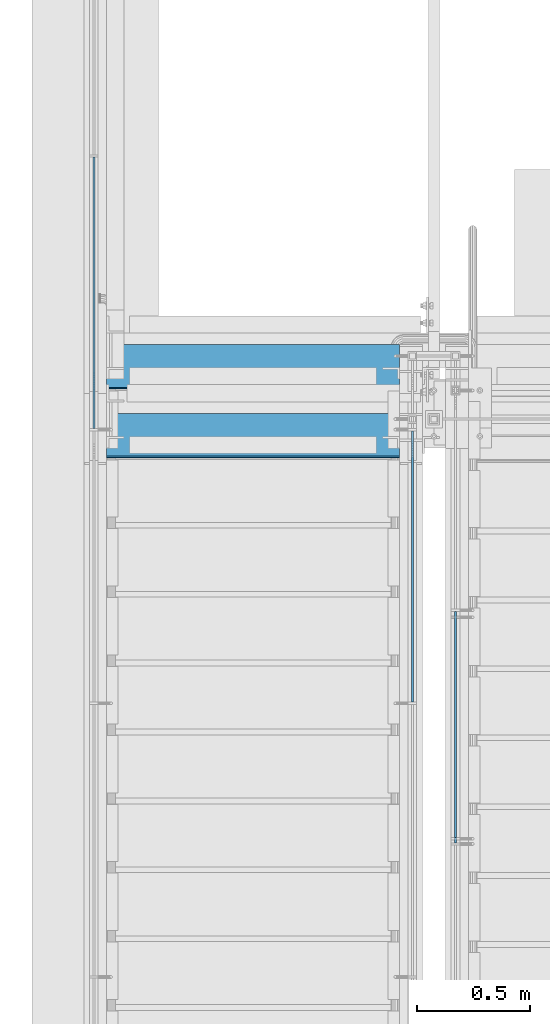
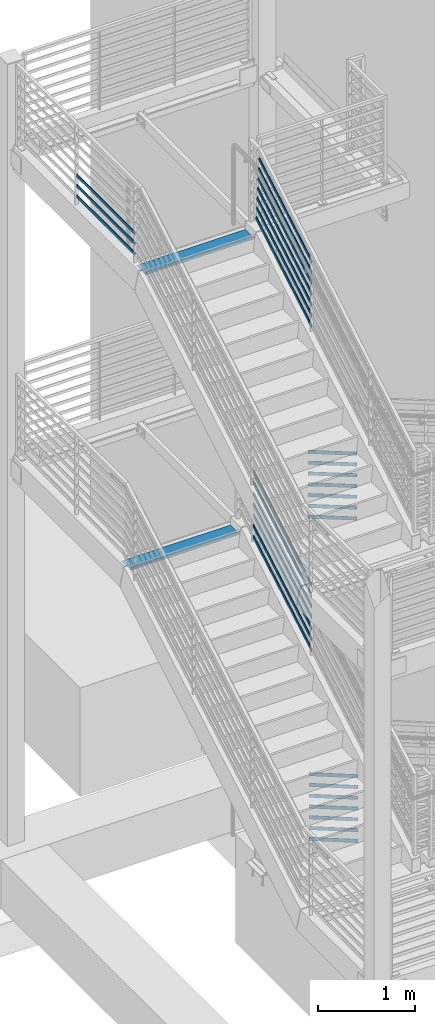
# One storey, part 758 of 1179: 28 members, 5 beams, 7 elements without a shape of their own.
"""IFC2X3 building model written with IfcOpenShell, lengths in millimetres."""

import ifcopenshell
import ifcopenshell.guid

model = None  # the IFC model being written
_history = None  # IfcOwnerHistory: only IFC2X3 demands one
_inside = {}  # id of a spatial element -> (the spatial element, [elements in it])
_under = {}  # id of a project, library or spatial element -> (it, [spatial elements below it])
_declared = {}  # id of a project -> (the project, [libraries it declares])
_typed = {}  # id of a type object -> (the type object, [elements of that type])
_made_of = {}  # id of a material, layer set ... -> (it, [elements and type objects made of it])


def new_model(schema):
    """Start an empty IFC model of exactly this schema.

    Asked for "IFC4X3", IfcOpenShell would pick the latest addendum, in which some entities
    have other attributes; the version numbers below select the first issue.
    IFC2X3 requires an IfcOwnerHistory on every rooted entity: one is made here for all.
    """
    global model, _history
    if schema == "IFC4X3":
        model = ifcopenshell.file(schema_version=(4, 3, 0, 0))
    else:
        model = ifcopenshell.file(schema=schema)
    _inside.clear()
    _under.clear()
    _declared.clear()
    _typed.clear()
    _made_of.clear()
    _history = None
    if model.schema == "IFC2X3":
        org = make("IfcOrganization", Name="unknown")
        user = make(
            "IfcPersonAndOrganization",
            ThePerson=make("IfcPerson", FamilyName="unknown"),
            TheOrganization=org,
        )
        app = make(
            "IfcApplication",
            ApplicationDeveloper=org,
            Version="unknown",
            ApplicationFullName="unknown",
            ApplicationIdentifier="unknown",
        )
        _history = make(
            "IfcOwnerHistory",
            OwningUser=user,
            OwningApplication=app,
            ChangeAction="ADDED",
            CreationDate=0,
        )
    return model


def make(cls, **values):
    """One entity of the class cls with the attributes given. An attribute that is None is left unset."""
    return model.create_entity(
        cls, **{name: value for name, value in values.items() if value is not None}
    )


def rooted(cls, **values):
    """An entity with a GlobalId (a new one), such as an element, a storey or a relation."""
    return make(cls, GlobalId=ifcopenshell.guid.new(), OwnerHistory=_history, **values)


def si_unit(unit_type, name, prefix=None):
    """IfcSIUnit, for example si_unit("LENGTHUNIT", "METRE", prefix="MILLI")."""
    return make("IfcSIUnit", UnitType=unit_type, Prefix=prefix, Name=name)


def assignment(units):
    """IfcUnitAssignment: the units of a project."""
    return None if units is None else make("IfcUnitAssignment", Units=units)


def point(xyz):
    """IfcCartesianPoint."""
    return None if xyz is None else make("IfcCartesianPoint", Coordinates=xyz)


def direction(xyz):
    """IfcDirection."""
    return None if xyz is None else make("IfcDirection", DirectionRatios=xyz)


def frame(location, z_axis=None, x_axis=None):
    """IfcAxis2Placement3D, a coordinate frame: its origin and axes. An axis left out is left unset."""
    return make(
        "IfcAxis2Placement3D",
        Location=point(location),
        Axis=direction(z_axis),
        RefDirection=direction(x_axis),
    )


def origin_with_axes():
    """The frame at (0, 0, 0) with the z axis (0, 0, 1) and the x axis (1, 0, 0) written out."""
    return frame((0.0, 0.0, 0.0), z_axis=(0.0, 0.0, 1.0), x_axis=(1.0, 0.0, 0.0))


def place(relative_to, where):
    """IfcLocalPlacement: puts the frame where relative to a parent placement (None: the world)."""
    return make(
        "IfcLocalPlacement", PlacementRelTo=relative_to, RelativePlacement=where
    )


def context(
    kind, dimensions, precision=None, world=None, true_north=None, identifier=None
):
    """IfcGeometricRepresentationContext, for example the 3D "Model" context."""
    return make(
        "IfcGeometricRepresentationContext",
        ContextIdentifier=identifier,
        ContextType=kind,
        CoordinateSpaceDimension=dimensions,
        Precision=precision,
        WorldCoordinateSystem=world,
        TrueNorth=true_north,
    )


def subcontext(parent, identifier, kind, view, scale=None):
    """IfcGeometricRepresentationSubContext, for example "Body" below "Model"."""
    return make(
        "IfcGeometricRepresentationSubContext",
        ContextIdentifier=identifier,
        ContextType=kind,
        ParentContext=parent,
        TargetScale=scale,
        TargetView=view,
    )


def project(units=None, contexts=None):
    """IfcProject with its units and contexts."""
    return rooted(
        "IfcProject",
        Name="project",
        RepresentationContexts=contexts,
        UnitsInContext=assignment(units),
    )


def spatial(cls, under=None, at=None, **own):
    """A site, building, storey or space (cls), placed at a placement, below another one or the project."""
    s = rooted(cls, ObjectPlacement=at, **own)
    if under is not None:
        _under.setdefault(under.id(), (under, []))[1].append(s)
    return s


def faces_of(points, faces, orient=None, outer=None):
    """IfcFace entities. A face is a list of loops; a loop is a list of indices into points, from 0.

    orient and outer hold one flag for each loop. By default every Orientation is true, the
    first loop of a face is its IfcFaceOuterBound and the others are IfcFaceBound.
    """
    made = []
    for i, loops in enumerate(faces):
        bounds = []
        for j, loop in enumerate(loops):
            is_outer = j == 0 if outer is None else outer[i][j]
            bounds.append(
                make(
                    "IfcFaceOuterBound" if is_outer else "IfcFaceBound",
                    Bound=make("IfcPolyLoop", Polygon=[points[k] for k in loop]),
                    Orientation=True if orient is None else orient[i][j],
                )
            )
        made.append(make("IfcFace", Bounds=bounds))
    return made


def faceted_brep(points, faces, orient=None, outer=None, voids=None):
    """IfcFacetedBrep: a solid bounded by flat faces; with voids (closed shells), ...WithVoids."""
    shared = [point(p) for p in points]
    hull = make("IfcClosedShell", CfsFaces=faces_of(shared, faces, orient, outer))
    if voids is None:
        return make("IfcFacetedBrep", Outer=hull)
    return make(
        "IfcFacetedBrepWithVoids",
        Outer=hull,
        Voids=[
            make(cls, CfsFaces=faces_of(shared, fs, o, b)) for cls, fs, o, b in voids
        ],
    )


def shape(context_of_items, identifier, shape_type, items):
    """IfcShapeRepresentation: the items that make up one representation, for example the "Body"."""
    return make(
        "IfcShapeRepresentation",
        ContextOfItems=context_of_items,
        RepresentationIdentifier=identifier,
        RepresentationType=shape_type,
        Items=items,
    )


def material(Name=None, Category=None):
    """IfcMaterial."""
    return make("IfcMaterial", Name=Name, Category=Category)


def made_of(thing, what):
    """Note that an element or type object is made of a material, layer set ...; save() writes the relation."""
    if what is not None:
        _made_of.setdefault(what.id(), (what, []))[1].append(thing)
    return thing


def type_object(cls, material=None, **own):
    """A type object (cls), such as IfcWallType, which elements share."""
    return made_of(rooted(cls, **own), material)


def element(
    cls,
    number,
    at=None,
    inside=None,
    cuts=None,
    type_object=None,
    material=None,
    context=None,
    identifier="Body",
    shape_type=None,
    held_by="IfcProductDefinitionShape",
    body=None,
    shapes=None,
    **own,
):
    """One element of the class cls, such as IfcWall. Its Tag is "e" and its number.

    at: its placement. inside: the storey or other place that contains it. cuts: it is an
    opening in that element (IfcRelVoidsElement). A single representation is given by context,
    identifier, shape_type and body (its items); several are given by shapes. held_by: the class
    of the entity that holds the representations. save() writes the other relations.
    """
    e = rooted(cls, Tag="e%d" % number, ObjectPlacement=at, **own)
    if body is not None:
        shapes = [shape(context, identifier, shape_type, body)]
    if shapes is not None:
        e.Representation = make(held_by, Representations=shapes)
    if inside is not None:
        _inside.setdefault(inside.id(), (inside, []))[1].append(e)
    if cuts is not None:
        rooted(
            "IfcRelVoidsElement", RelatingBuildingElement=cuts, RelatedOpeningElement=e
        )
    if type_object is not None:
        _typed.setdefault(type_object.id(), (type_object, []))[1].append(e)
    return made_of(e, material)


def aggregate(whole, parts):
    """IfcRelAggregates: a whole, such as a stair, and the parts it consists of."""
    return rooted("IfcRelAggregates", RelatingObject=whole, RelatedObjects=parts)


def save(model, path):
    """Write the relations noted so far, then the file.

    IfcRelAggregates (storeys below a building ...), IfcRelContainedInSpatialStructure (elements
    in a storey), IfcRelDefinesByType, IfcRelAssociatesMaterial and IfcRelDeclares: one each for
    every whole, place, type object, material and project.
    """
    for whole, parts in _under.values():
        aggregate(whole, parts)
    for where, things in _inside.values():
        rooted(
            "IfcRelContainedInSpatialStructure",
            RelatedElements=things,
            RelatingStructure=where,
        )
    for kind, things in _typed.values():
        rooted("IfcRelDefinesByType", RelatedObjects=things, RelatingType=kind)
    for what, things in _made_of.values():
        rooted("IfcRelAssociatesMaterial", RelatedObjects=things, RelatingMaterial=what)
    for by, libraries in _declared.values():
        rooted("IfcRelDeclares", RelatingContext=by, RelatedDefinitions=libraries)
    model.write(path)


model = new_model("IFC2X3")

# Units and contexts
model_context = context("Model", 3, precision=1e-05, world=origin_with_axes())
body_context = subcontext(model_context, "Body", "Model", "MODEL_VIEW")
ifc_project = project(units=[si_unit("LENGTHUNIT", "METRE", prefix="MILLI"), si_unit("AREAUNIT", "SQUARE_METRE"), si_unit("VOLUMEUNIT", "CUBIC_METRE"), si_unit("MASSUNIT", "GRAM", prefix="KILO"), si_unit("TIMEUNIT", "SECOND"), si_unit("PLANEANGLEUNIT", "RADIAN"), si_unit("SOLIDANGLEUNIT", "STERADIAN"), si_unit("THERMODYNAMICTEMPERATUREUNIT", "DEGREE_CELSIUS"), si_unit("LUMINOUSINTENSITYUNIT", "LUMEN")], contexts=[model_context])

# Site, building, storey
site_placement = place(None, origin_with_axes())
site = spatial("IfcSite", under=ifc_project, at=site_placement, CompositionType="ELEMENT")
building_placement = place(site_placement, origin_with_axes())
building = spatial("IfcBuilding", under=site, at=building_placement, Name="Undefined", CompositionType="ELEMENT")
storey_placement = place(building_placement, origin_with_axes())
storey = spatial("IfcBuildingStorey", under=building, at=storey_placement, Name="Undefined", CompositionType="ELEMENT", Elevation=0.0)

# Assembly, beam
assembly_1_placement = place(storey_placement, origin_with_axes())
assembly_1 = element("IfcElementAssembly", 1, at=assembly_1_placement, inside=storey, Name="STRINGER", AssemblyPlace="NOTDEFINED", PredefinedType="RIGID_FRAME")
ifc_material = material(Name="STEEL/A36")
beam_type_1 = type_object("IfcBeamType", PredefinedType="NOTDEFINED")
beam_1_placement = place(assembly_1_placement, frame((-2552.70000000004, 34944.8910299301, 8130.51961359686), z_axis=(-1.0, 0.0, 0.0), x_axis=(0.0, 0.142453053944999, -0.989801559617757)))
beam_1 = element("IfcBeam", 2, at=beam_1_placement, type_object=beam_type_1, material=ifc_material, Name="TREAD", context=body_context, shape_type="Brep", body=[
    faceted_brep([(-5.47515810467303e-10, -1.58750000000146, -647.7), (-5.47515810467303e-10, -1.58750000000146, 647.7), (5.49334799870849e-10, 1.58749999999418, 647.7), (5.49334799870849e-10, 1.58749999999418, -647.7), (37.6019506244984, 1.58749998704297, 647.7), (37.6019506244984, 1.58749998704297, -647.7), (34.8511855571105, -1.58750001201406, -647.7), (34.8511855571105, -1.58750001201406, 647.7), (64.9848133561491, -188.675884943717, 647.7), (64.9848133561491, -188.675884943717, -647.7), (61.8421934043654, -189.128173390025, 647.7), (61.8421934043654, -189.128173390025, -647.7)], [[[0, 1, 2, 3]], [[3, 2, 4, 5]], [[1, 0, 6, 7]], [[5, 4, 8, 9]], [[4, 2, 1, 7, 10, 8]], [[7, 6, 11, 10]], [[6, 0, 3, 5, 9, 11]], [[10, 11, 9, 8]]]),
])
aggregate(assembly_1, [beam_1])

assembly_2_placement = place(storey_placement, origin_with_axes())
assembly_2 = element("IfcElementAssembly", 3, at=assembly_2_placement, inside=storey, Name="STRINGER", AssemblyPlace="NOTDEFINED", PredefinedType="RIGID_FRAME")
beam_2_placement = place(assembly_2_placement, frame((-2552.70000000004, 35249.6910299626, 4218.91961359472), z_axis=(-1.0, 0.0, 0.0), x_axis=(0.0, 0.142453053944999, -0.989801559617757)))
beam_2 = element("IfcBeam", 4, at=beam_2_placement, type_object=beam_type_1, material=ifc_material, Name="TREAD", context=body_context, shape_type="Brep", body=[
    faceted_brep([(-5.47515810467303e-10, -1.58750000000146, -647.7), (-5.47515810467303e-10, -1.58750000000146, 647.7), (5.49334799870849e-10, 1.58749999999418, 647.7), (5.49334799870849e-10, 1.58749999999418, -647.7), (37.6019506244984, 1.58749998704297, 647.7), (37.6019506244984, 1.58749998704297, -647.7), (34.8511855571105, -1.58750001201406, -647.7), (34.8511855571105, -1.58750001201406, 647.7), (64.9848133561491, -188.675884943717, 647.7), (64.9848133561491, -188.675884943717, -647.7), (61.8421934043654, -189.128173390025, 647.7), (61.8421934043654, -189.128173390025, -647.7)], [[[0, 1, 2, 3]], [[3, 2, 4, 5]], [[1, 0, 6, 7]], [[5, 4, 8, 9]], [[4, 2, 1, 7, 10, 8]], [[7, 6, 11, 10]], [[6, 0, 3, 5, 9, 11]], [[10, 11, 9, 8]]]),
])
aggregate(assembly_2, [beam_2])

# Assembly, beams
assembly_3_placement = place(storey_placement, origin_with_axes())
assembly_3 = element("IfcElementAssembly", 5, at=assembly_3_placement, inside=storey, Name="GUARDRAIL", AssemblyPlace="NOTDEFINED", PredefinedType="RIGID_FRAME")
beam_type_2 = type_object("IfcBeamType", PredefinedType="NOTDEFINED")
beam_3_placement = place(assembly_3_placement, frame((-3257.54999923555, 36279.6666666667, 8305.78812688398), z_axis=(0.0, 0.0, 1.0), x_axis=(0.0, -1.0, 0.0)))
beam_3 = element("IfcBeam", 6, at=beam_3_placement, type_object=beam_type_2, material=ifc_material, Name="PLATE", context=body_context, shape_type="Brep", body=[
    faceted_brep([(4.76250000197615, 4.76249999999999, -19.0500000000002), (4.76250000197615, 4.76249999999999, 19.0500000000002), (1205.97083333334, 4.76249999999982, 19.0499999999993), (1205.97083333334, 4.76249999999982, -19.0499999999993), (4.76250000197615, -4.76249999999999, 19.0500000000002), (1205.97083333334, -4.76249999999982, 19.0499999999993), (4.76250000197615, -4.76249999999999, -19.0500000000002), (1205.97083333334, -4.76249999999982, -19.0499999999993)], [[[0, 1, 2, 3]], [[1, 4, 5, 2]], [[4, 6, 7, 5]], [[6, 0, 3, 7]], [[5, 7, 3, 2]], [[6, 4, 1, 0]]]),
])
beam_4_placement = place(assembly_3_placement, frame((-3257.54999923555, 36279.6666666667, 8435.96312688397), z_axis=(0.0, 0.0, 1.0), x_axis=(0.0, -1.0, 0.0)))
beam_4 = element("IfcBeam", 7, at=beam_4_placement, type_object=beam_type_2, material=ifc_material, Name="PLATE", context=body_context, shape_type="Brep", body=[
    faceted_brep([(4.76250000197615, 4.76249999999999, -19.0500000000002), (4.76250000197615, 4.76249999999999, 19.0500000000002), (1205.97083333334, 4.76249999999982, 19.0499999999993), (1205.97083333334, 4.76249999999982, -19.0499999999993), (4.76250000197615, -4.76249999999999, 19.0500000000002), (1205.97083333334, -4.76249999999982, 19.0499999999993), (4.76250000197615, -4.76249999999999, -19.0500000000002), (1205.97083333334, -4.76249999999982, -19.0499999999993)], [[[0, 1, 2, 3]], [[1, 4, 5, 2]], [[4, 6, 7, 5]], [[6, 0, 3, 7]], [[5, 7, 3, 2]], [[6, 4, 1, 0]]]),
])
beam_5_placement = place(assembly_3_placement, frame((-3257.54999923555, 36279.6666666667, 8566.13812688397), z_axis=(0.0, 0.0, 1.0), x_axis=(0.0, -1.0, 0.0)))
beam_5 = element("IfcBeam", 8, at=beam_5_placement, type_object=beam_type_2, material=ifc_material, Name="PLATE", context=body_context, shape_type="Brep", body=[
    faceted_brep([(4.76250000197615, 4.76249999999999, -19.0500000000002), (4.76250000197615, 4.76249999999999, 19.0500000000002), (1205.97083333334, 4.76249999999982, 19.0499999999993), (1205.97083333334, 4.76249999999982, -19.0499999999993), (4.76250000197615, -4.76249999999999, 19.0500000000002), (1205.97083333334, -4.76249999999982, 19.0499999999993), (4.76250000197615, -4.76249999999999, -19.0500000000002), (1205.97083333334, -4.76249999999982, -19.0499999999993)], [[[0, 1, 2, 3]], [[1, 4, 5, 2]], [[4, 6, 7, 5]], [[6, 0, 3, 7]], [[5, 7, 3, 2]], [[6, 4, 1, 0]]]),
])
aggregate(assembly_3, [beam_3, beam_4, beam_5])

# Assembly, members
assembly_4_placement = place(storey_placement, origin_with_axes())
assembly_4 = element("IfcElementAssembly", 9, at=assembly_4_placement, inside=storey, Name="GUARDRAIL", AssemblyPlace="NOTDEFINED", PredefinedType="RIGID_FRAME")
member_type = type_object("IfcMemberType", PredefinedType="NOTDEFINED")
member_1_placement = place(assembly_4_placement, frame((-1847.85000153055, 35022.9653816585, 8312.30172653875), z_axis=(0.0, -0.503864876039814, 0.863782488068254), x_axis=(0.0, -0.863782488068254, -0.503864876039814)))
member_1 = element("IfcMember", 10, at=member_1_placement, type_object=member_type, material=ifc_material, Name="PLATE", context=body_context, shape_type="Brep", body=[
    faceted_brep([(18.0090376689841, 4.76250000000005, -19.0499999999538), (7.70888092478708, 4.76250000000005, 19.049999999992), (1331.82169315177, 4.76250000000005, 19.0500000018928), (1354.04632961107, 4.76250000000005, -19.0499999980329), (7.70888092478708, -4.76250000000005, 19.049999999992), (1331.82169315177, -4.76250000000005, 19.0500000018928), (18.0090376689841, -4.76250000000005, -19.0499999999538), (1354.04632961107, -4.76250000000005, -19.0499999980329)], [[[0, 1, 2, 3]], [[1, 4, 5, 2]], [[4, 6, 7, 5]], [[6, 0, 3, 7]], [[5, 7, 3, 2]], [[6, 4, 1, 0]]]),
])
member_2_placement = place(assembly_4_placement, frame((-1847.85000153055, 35012.0608890004, 8442.13530455055), z_axis=(0.0, -0.503871025834967, 0.863778900717086), x_axis=(0.0, -0.863778900717086, -0.503871025834967)))
member_2 = element("IfcMember", 11, at=member_2_placement, type_object=member_type, material=ifc_material, Name="PLATE", context=body_context, shape_type="Brep", body=[
    faceted_brep([(17.3313555166387, 4.76250000000005, -19.049999999992), (7.03105325247452, 4.76250000000005, 19.0500000000447), (1319.20291756878, 4.76250000000005, 19.0500000022403), (1341.42791758705, 4.76250000000005, -19.0499999977765), (7.03105325247452, -4.76250000000005, 19.0500000000447), (1319.20291756878, -4.76250000000005, 19.0500000022403), (17.3313555166387, -4.76250000000005, -19.049999999992), (1341.42791758705, -4.76250000000005, -19.0499999977765)], [[[0, 1, 2, 3]], [[1, 4, 5, 2]], [[4, 6, 7, 5]], [[6, 0, 3, 7]], [[5, 7, 3, 2]], [[6, 4, 1, 0]]]),
])
member_3_placement = place(assembly_4_placement, frame((-1847.85000153055, 35001.1751747237, 8571.96881422631), z_axis=(0.0, -0.503871025834967, 0.863778900717086), x_axis=(0.0, -0.863778900717086, -0.503871025834967)))
member_3 = element("IfcMember", 12, at=member_3_placement, type_object=member_type, material=ifc_material, Name="PLATE", context=body_context, shape_type="Brep", body=[
    faceted_brep([(16.6536219166956, 4.76250000000005, -19.0499999999975), (6.35331965253863, 4.76250000000005, 19.0500000000393), (1306.60048624325, 4.76250000000005, 19.0500000022148), (1328.82548626152, 4.76250000000005, -19.0499999978038), (6.35331965253863, -4.76250000000005, 19.0500000000393), (1306.60048624325, -4.76250000000005, 19.0500000022148), (16.6536219166956, -4.76250000000005, -19.0499999999975), (1328.82548626152, -4.76250000000005, -19.0499999978038)], [[[0, 1, 2, 3]], [[1, 4, 5, 2]], [[4, 6, 7, 5]], [[6, 0, 3, 7]], [[5, 7, 3, 2]], [[6, 4, 1, 0]]]),
])
member_4_placement = place(assembly_4_placement, frame((-1847.85000153055, 34990.3077024366, 8701.80225557424), z_axis=(0.0, -0.503864876039814, 0.863782488068254), x_axis=(0.0, -0.863782488068254, -0.503864876039814)))
member_4 = element("IfcMember", 13, at=member_4_placement, type_object=member_type, material=ifc_material, Name="PLATE", context=body_context, shape_type="Brep", body=[
    faceted_brep([(15.9758120578772, 4.76250000000005, -19.0500000000011), (5.67565529743297, 4.76250000000005, 19.0500000000266), (1294.01393621509, 4.76250000000005, 19.050000001429), (1316.238572744, 4.76250000000005, -19.0499999985877), (5.67565529743297, -4.76250000000005, 19.0500000000266), (1294.01393621509, -4.76250000000005, 19.050000001429), (15.9758120578772, -4.76250000000005, -19.0500000000011), (1316.238572744, -4.76250000000005, -19.0499999985877)], [[[0, 1, 2, 3]], [[1, 4, 5, 2]], [[4, 6, 7, 5]], [[6, 0, 3, 7]], [[5, 7, 3, 2]], [[6, 4, 1, 0]]]),
])
member_5_placement = place(assembly_4_placement, frame((-1847.85000153055, 34979.4218093629, 8831.63576525283), z_axis=(0.0, -0.503864876039814, 0.863782488068254), x_axis=(0.0, -0.863782488068254, -0.503864876039814)))
member_5 = element("IfcMember", 14, at=member_5_placement, type_object=member_type, material=ifc_material, Name="PLATE", context=body_context, shape_type="Brep", body=[
    faceted_brep([(15.2980701932393, 4.76250000000005, -19.0500000000047), (4.99791343278775, 4.76250000000005, 19.0500000000229), (1281.41135022522, 4.76250000000005, 19.0500000014144), (1303.63598675413, 4.76250000000005, -19.0499999986005), (4.99791343278775, -4.76250000000005, 19.0500000000229), (1281.41135022522, -4.76250000000005, 19.0500000014144), (15.2980701932393, -4.76250000000005, -19.0500000000047), (1303.63598675413, -4.76250000000005, -19.0499999986005)], [[[0, 1, 2, 3]], [[1, 4, 5, 2]], [[4, 6, 7, 5]], [[6, 0, 3, 7]], [[5, 7, 3, 2]], [[6, 4, 1, 0]]]),
])
member_6_placement = place(assembly_4_placement, frame((-1847.85000153055, 34968.5359162894, 8961.46927493018), z_axis=(0.0, -0.503864876039814, 0.863782488068254), x_axis=(0.0, -0.863782488068254, -0.503864876039814)))
member_6 = element("IfcMember", 15, at=member_6_placement, type_object=member_type, material=ifc_material, Name="PLATE", context=body_context, shape_type="Brep", body=[
    faceted_brep([(14.6203283212453, 4.76250000000005, -19.0499999999793), (4.32017152535991, 4.76250000000005, 19.0499999999938), (1268.80876485228, 4.76250000000005, 19.0500000008888), (1291.03340142537, 4.76250000000005, -19.0499999990752), (4.32017152535991, -4.76250000000005, 19.0499999999938), (1268.80876485228, -4.76250000000005, 19.0500000008888), (14.6203283212453, -4.76250000000005, -19.0499999999793), (1291.03340142537, -4.76250000000005, -19.0499999990752)], [[[0, 1, 2, 3]], [[1, 4, 5, 2]], [[4, 6, 7, 5]], [[6, 0, 3, 7]], [[5, 7, 3, 2]], [[6, 4, 1, 0]]]),
])
member_7_placement = place(assembly_4_placement, frame((-1847.85000153055, 34957.6501403332, 9091.31324949527), z_axis=(0.0, -0.503871025834967, 0.863778900717086), x_axis=(0.0, -0.863778900717086, -0.503871025834967)))
member_7 = element("IfcMember", 16, at=member_7_placement, type_object=member_type, material=ifc_material, Name="PLATE", context=body_context, shape_type="Brep", body=[
    faceted_brep([(13.9633209040476, 4.76249999999982, -19.0499999999993), (3.66301863989065, 4.76249999999982, 19.0500000000393), (1256.21139436502, 4.76249999999982, 19.0500000021311), (1278.43639438329, 4.76249999999982, -19.0499999978838), (3.66301863989065, -4.76250000000027, 19.0500000000393), (1256.21139436502, -4.76250000000027, 19.0500000021311), (13.9633209040476, -4.76250000000027, -19.0499999999993), (1278.43639438329, -4.76250000000027, -19.0499999978838)], [[[0, 1, 2, 3]], [[1, 4, 5, 2]], [[4, 6, 7, 5]], [[6, 0, 3, 7]], [[5, 7, 3, 2]], [[6, 4, 1, 0]]]),
])
aggregate(assembly_4, [member_1, member_2, member_3, member_4, member_5, member_6, member_7])

assembly_5_placement = place(storey_placement, origin_with_axes())
assembly_5 = element("IfcElementAssembly", 17, at=assembly_5_placement, inside=storey, Name="GUARDRAIL", AssemblyPlace="NOTDEFINED", PredefinedType="RIGID_FRAME")
member_8_placement = place(assembly_5_placement, frame((-1847.85000076555, 35078.4786384036, 4257.05120596726), z_axis=(0.0, -0.501065882891537, 0.865409140812671), x_axis=(0.0, -0.86540914081267, -0.501065882891538)))
member_8 = element("IfcMember", 18, at=member_8_placement, type_object=member_type, material=ifc_material, Name="PLATE", context=body_context, shape_type="Brep", body=[
    faceted_brep([(27.5628128089447, 4.76250000000005, -19.0499999999756), (5.50317738577724, 4.76250000000005, 19.0499999999902), (1393.52680304928, 4.76249999999982, 19.0499999980784), (1415.58643847238, 4.76249999999982, -19.0500000019292), (5.50317738577724, -4.76250000000005, 19.0499999999902), (1393.52680304928, -4.76250000000027, 19.0499999980784), (27.5628128089447, -4.76250000000005, -19.0499999999756), (1415.58643847238, -4.76250000000027, -19.0500000019292)], [[[0, 1, 2, 3]], [[1, 4, 5, 2]], [[4, 6, 7, 5]], [[6, 0, 3, 7]], [[5, 7, 3, 2]], [[6, 4, 1, 0]]]),
])
member_9_placement = place(assembly_5_placement, frame((-1847.85000076555, 35078.4786384036, 4393.15162493177), z_axis=(0.0, -0.501065882891537, 0.865409140812671), x_axis=(0.0, -0.86540914081267, -0.501065882891538)))
member_9 = element("IfcMember", 19, at=member_9_placement, type_object=member_type, material=ifc_material, Name="PLATE", context=body_context, shape_type="Brep", body=[
    faceted_brep([(27.5628128089447, 4.76250000000005, -19.0499999999756), (5.50317738577724, 4.76250000000005, 19.0499999999902), (1393.52680304928, 4.76249999999982, 19.0499999980784), (1415.58643847238, 4.76249999999982, -19.0500000019292), (5.50317738577724, -4.76250000000005, 19.0499999999902), (1393.52680304928, -4.76250000000027, 19.0499999980784), (27.5628128089447, -4.76250000000005, -19.0499999999756), (1415.58643847238, -4.76250000000027, -19.0500000019292)], [[[0, 1, 2, 3]], [[1, 4, 5, 2]], [[4, 6, 7, 5]], [[6, 0, 3, 7]], [[5, 7, 3, 2]], [[6, 4, 1, 0]]]),
])
member_10_placement = place(assembly_5_placement, frame((-1847.85000076555, 35078.4786384036, 4529.25204389628), z_axis=(0.0, -0.501065882891537, 0.865409140812671), x_axis=(0.0, -0.86540914081267, -0.501065882891538)))
member_10 = element("IfcMember", 20, at=member_10_placement, type_object=member_type, material=ifc_material, Name="PLATE", context=body_context, shape_type="Brep", body=[
    faceted_brep([(27.5628128089447, 4.76250000000005, -19.0499999999756), (5.50317738577724, 4.76250000000005, 19.0499999999902), (1393.52680304928, 4.76249999999982, 19.0499999980784), (1415.58643847238, 4.76249999999982, -19.0500000019292), (5.50317738577724, -4.76250000000005, 19.0499999999902), (1393.52680304928, -4.76250000000027, 19.0499999980784), (27.5628128089447, -4.76250000000005, -19.0499999999756), (1415.58643847238, -4.76250000000027, -19.0500000019292)], [[[0, 1, 2, 3]], [[1, 4, 5, 2]], [[4, 6, 7, 5]], [[6, 0, 3, 7]], [[5, 7, 3, 2]], [[6, 4, 1, 0]]]),
])
member_11_placement = place(assembly_5_placement, frame((-1847.85000076555, 35078.4786384036, 4665.35246286079), z_axis=(0.0, -0.501065882891537, 0.865409140812671), x_axis=(0.0, -0.86540914081267, -0.501065882891538)))
member_11 = element("IfcMember", 21, at=member_11_placement, type_object=member_type, material=ifc_material, Name="PLATE", context=body_context, shape_type="Brep", body=[
    faceted_brep([(27.5628128089447, 4.76250000000005, -19.0499999999756), (5.50317738577724, 4.76250000000005, 19.0499999999902), (1393.52680304928, 4.76249999999982, 19.0499999980784), (1415.58643847238, 4.76249999999982, -19.0500000019292), (5.50317738577724, -4.76250000000005, 19.0499999999902), (1393.52680304928, -4.76250000000027, 19.0499999980784), (27.5628128089447, -4.76250000000005, -19.0499999999756), (1415.58643847238, -4.76250000000027, -19.0500000019292)], [[[0, 1, 2, 3]], [[1, 4, 5, 2]], [[4, 6, 7, 5]], [[6, 0, 3, 7]], [[5, 7, 3, 2]], [[6, 4, 1, 0]]]),
])
member_12_placement = place(assembly_5_placement, frame((-1847.85000076555, 35078.4786384035, 4801.4528818253), z_axis=(0.0, -0.501065882891537, 0.865409140812671), x_axis=(0.0, -0.86540914081267, -0.501065882891538)))
member_12 = element("IfcMember", 22, at=member_12_placement, type_object=member_type, material=ifc_material, Name="PLATE", context=body_context, shape_type="Brep", body=[
    faceted_brep([(27.5628128089447, 4.76250000000005, -19.0499999999756), (5.50317738577724, 4.76250000000005, 19.0499999999902), (1393.52680304928, 4.76249999999982, 19.0499999980784), (1415.58643847238, 4.76249999999982, -19.0500000019292), (5.50317738577724, -4.76250000000005, 19.0499999999902), (1393.52680304928, -4.76250000000027, 19.0499999980784), (27.5628128089447, -4.76250000000005, -19.0499999999756), (1415.58643847238, -4.76250000000027, -19.0500000019292)], [[[0, 1, 2, 3]], [[1, 4, 5, 2]], [[4, 6, 7, 5]], [[6, 0, 3, 7]], [[5, 7, 3, 2]], [[6, 4, 1, 0]]]),
])
member_13_placement = place(assembly_5_placement, frame((-1847.85000076555, 35078.4786384033, 4937.5533007898), z_axis=(0.0, -0.501065882891537, 0.865409140812671), x_axis=(0.0, -0.86540914081267, -0.501065882891538)))
member_13 = element("IfcMember", 23, at=member_13_placement, type_object=member_type, material=ifc_material, Name="PLATE", context=body_context, shape_type="Brep", body=[
    faceted_brep([(27.5628128089447, 4.76250000000005, -19.0499999999756), (5.50317738577724, 4.76250000000005, 19.0499999999902), (1393.52680304928, 4.76249999999982, 19.0499999980784), (1415.58643847238, 4.76249999999982, -19.0500000019292), (5.50317738577724, -4.76250000000005, 19.0499999999902), (1393.52680304928, -4.76250000000027, 19.0499999980784), (27.5628128089447, -4.76250000000005, -19.0499999999756), (1415.58643847238, -4.76250000000027, -19.0500000019292)], [[[0, 1, 2, 3]], [[1, 4, 5, 2]], [[4, 6, 7, 5]], [[6, 0, 3, 7]], [[5, 7, 3, 2]], [[6, 4, 1, 0]]]),
])
member_14_placement = place(assembly_5_placement, frame((-1847.85000076555, 35078.4786384021, 5073.65371975431), z_axis=(0.0, -0.501065882891537, 0.865409140812671), x_axis=(0.0, -0.86540914081267, -0.501065882891538)))
member_14 = element("IfcMember", 24, at=member_14_placement, type_object=member_type, material=ifc_material, Name="PLATE", context=body_context, shape_type="Brep", body=[
    faceted_brep([(27.5628128089447, 4.76250000000005, -19.0499999999756), (5.50317738577724, 4.76250000000005, 19.0499999999902), (1393.52680304928, 4.76249999999982, 19.0499999980784), (1415.58643847238, 4.76249999999982, -19.0500000019292), (5.50317738577724, -4.76250000000005, 19.0499999999902), (1393.52680304928, -4.76250000000027, 19.0499999980784), (27.5628128089447, -4.76250000000005, -19.0499999999756), (1415.58643847238, -4.76250000000027, -19.0500000019292)], [[[0, 1, 2, 3]], [[1, 4, 5, 2]], [[4, 6, 7, 5]], [[6, 0, 3, 7]], [[5, 7, 3, 2]], [[6, 4, 1, 0]]]),
])
aggregate(assembly_5, [member_8, member_9, member_10, member_11, member_12, member_13, member_14])

assembly_6_placement = place(storey_placement, origin_with_axes())
assembly_6 = element("IfcElementAssembly", 25, at=assembly_6_placement, inside=storey, Name="GUARDRAIL", AssemblyPlace="NOTDEFINED", PredefinedType="RIGID_FRAME")
member_15_placement = place(assembly_6_placement, frame((-1657.3499991948, 34260.0809196835, 5739.15563064207), z_axis=(0.0, 0.503871025834968, 0.863778900717086), x_axis=(0.0, -0.863778900717086, 0.503871025834967)))
member_15 = element("IfcMember", 26, at=member_15_placement, type_object=member_type, material=ifc_material, Name="PLATE", context=body_context, shape_type="Brep", body=[
    faceted_brep([(-16.7114354625264, 4.76250000000005, -19.0500000000065), (5.51356370517169, 4.76250000000005, 19.0500000000338), (1164.83261782332, 4.76250000000005, 19.0499999989988), (1142.607617805, 4.76250000000005, -19.0500000010361), (5.51356370517169, -4.76250000000005, 19.0500000000338), (1164.83261782332, -4.76250000000005, 19.0499999989988), (-16.7114354625264, -4.76250000000005, -19.0500000000065), (1142.607617805, -4.76250000000005, -19.0500000010361)], [[[0, 1, 2, 3]], [[1, 4, 5, 2]], [[4, 6, 7, 5]], [[6, 0, 3, 7]], [[5, 7, 3, 2]], [[6, 4, 1, 0]]]),
])
member_16_placement = place(assembly_6_placement, frame((-1657.3499991948, 34260.0809195598, 5602.9721209663), z_axis=(0.0, 0.503871025834968, 0.863778900717086), x_axis=(0.0, -0.863778900717086, 0.503871025834967)))
member_16 = element("IfcMember", 27, at=member_16_placement, type_object=member_type, material=ifc_material, Name="PLATE", context=body_context, shape_type="Brep", body=[
    faceted_brep([(-16.7114354625264, 4.76250000000005, -19.0500000000065), (5.51356370517169, 4.76250000000005, 19.0500000000338), (1164.83261782332, 4.76250000000005, 19.0499999989988), (1142.607617805, 4.76250000000005, -19.0500000010361), (5.51356370517169, -4.76250000000005, 19.0500000000338), (1164.83261782332, -4.76250000000005, 19.0499999989988), (-16.7114354625264, -4.76250000000005, -19.0500000000065), (1142.607617805, -4.76250000000005, -19.0500000010361)], [[[0, 1, 2, 3]], [[1, 4, 5, 2]], [[4, 6, 7, 5]], [[6, 0, 3, 7]], [[5, 7, 3, 2]], [[6, 4, 1, 0]]]),
])
member_17_placement = place(assembly_6_placement, frame((-1657.3499991948, 34260.0809194158, 5466.78861129053), z_axis=(0.0, 0.503871025834968, 0.863778900717086), x_axis=(0.0, -0.863778900717086, 0.503871025834967)))
member_17 = element("IfcMember", 28, at=member_17_placement, type_object=member_type, material=ifc_material, Name="PLATE", context=body_context, shape_type="Brep", body=[
    faceted_brep([(-16.7114354625264, 4.76250000000005, -19.0500000000065), (5.51356370517169, 4.76250000000005, 19.0500000000338), (1164.83261782332, 4.76250000000005, 19.0499999989988), (1142.607617805, 4.76250000000005, -19.0500000010361), (5.51356370517169, -4.76250000000005, 19.0500000000338), (1164.83261782332, -4.76250000000005, 19.0499999989988), (-16.7114354625264, -4.76250000000005, -19.0500000000065), (1142.607617805, -4.76250000000005, -19.0500000010361)], [[[0, 1, 2, 3]], [[1, 4, 5, 2]], [[4, 6, 7, 5]], [[6, 0, 3, 7]], [[5, 7, 3, 2]], [[6, 4, 1, 0]]]),
])
member_18_placement = place(assembly_6_placement, frame((-1657.3499991948, 34260.0805979079, 5330.60510161533), z_axis=(0.0, 0.503871025834968, 0.863778900717086), x_axis=(0.0, -0.863778900717086, 0.503871025834967)))
member_18 = element("IfcMember", 29, at=member_18_placement, type_object=member_type, material=ifc_material, Name="PLATE", context=body_context, shape_type="Brep", body=[
    faceted_brep([(-16.7114354625264, 4.76250000000005, -19.0500000000065), (5.51356370517169, 4.76250000000005, 19.0500000000338), (1164.83261782332, 4.76250000000005, 19.0499999989988), (1142.607617805, 4.76250000000005, -19.0500000010361), (5.51356370517169, -4.76250000000005, 19.0500000000338), (1164.83261782332, -4.76250000000005, 19.0499999989988), (-16.7114354625264, -4.76250000000005, -19.0500000000065), (1142.607617805, -4.76250000000005, -19.0500000010361)], [[[0, 1, 2, 3]], [[1, 4, 5, 2]], [[4, 6, 7, 5]], [[6, 0, 3, 7]], [[5, 7, 3, 2]], [[6, 4, 1, 0]]]),
])
member_19_placement = place(assembly_6_placement, frame((-1657.3499991948, 34260.0810218614, 5194.42159194055), z_axis=(0.0, 0.503871025834968, 0.863778900717086), x_axis=(0.0, -0.863778900717086, 0.503871025834967)))
member_19 = element("IfcMember", 30, at=member_19_placement, type_object=member_type, material=ifc_material, Name="PLATE", context=body_context, shape_type="Brep", body=[
    faceted_brep([(-16.7114354625264, 4.76250000000005, -19.0500000000065), (5.51356370517169, 4.76250000000005, 19.0500000000338), (1164.83261782332, 4.76250000000005, 19.0499999989988), (1142.607617805, 4.76250000000005, -19.0500000010361), (5.51356370517169, -4.76250000000005, 19.0500000000338), (1164.83261782332, -4.76250000000005, 19.0499999989988), (-16.7114354625264, -4.76250000000005, -19.0500000000065), (1142.607617805, -4.76250000000005, -19.0500000010361)], [[[0, 1, 2, 3]], [[1, 4, 5, 2]], [[4, 6, 7, 5]], [[6, 0, 3, 7]], [[5, 7, 3, 2]], [[6, 4, 1, 0]]]),
])
member_20_placement = place(assembly_6_placement, frame((-1657.3499991948, 34260.0808573954, 5058.23808226493), z_axis=(0.0, 0.503871025834968, 0.863778900717086), x_axis=(0.0, -0.863778900717086, 0.503871025834967)))
member_20 = element("IfcMember", 31, at=member_20_placement, type_object=member_type, material=ifc_material, Name="PLATE", context=body_context, shape_type="Brep", body=[
    faceted_brep([(-16.7114354625264, 4.76250000000005, -19.0500000000065), (5.51356370517169, 4.76250000000005, 19.0500000000338), (1164.83261782332, 4.76250000000005, 19.0499999989988), (1142.607617805, 4.76250000000005, -19.0500000010361), (5.51356370517169, -4.76250000000005, 19.0500000000338), (1164.83261782332, -4.76250000000005, 19.0499999989988), (-16.7114354625264, -4.76250000000005, -19.0500000000065), (1142.607617805, -4.76250000000005, -19.0500000010361)], [[[0, 1, 2, 3]], [[1, 4, 5, 2]], [[4, 6, 7, 5]], [[6, 0, 3, 7]], [[5, 7, 3, 2]], [[6, 4, 1, 0]]]),
])
member_21_placement = place(assembly_6_placement, frame((-1657.3499991948, 34260.0809647275, 4922.05457258923), z_axis=(0.0, 0.503871025834968, 0.863778900717086), x_axis=(0.0, -0.863778900717086, 0.503871025834967)))
member_21 = element("IfcMember", 32, at=member_21_placement, type_object=member_type, material=ifc_material, Name="PLATE", context=body_context, shape_type="Brep", body=[
    faceted_brep([(-16.7114354625264, 4.76250000000005, -19.0500000000065), (5.51356370517169, 4.76250000000005, 19.0500000000338), (1164.83261782332, 4.76250000000005, 19.0499999989988), (1142.607617805, 4.76250000000005, -19.0500000010361), (5.51356370517169, -4.76250000000005, 19.0500000000338), (1164.83261782332, -4.76250000000005, 19.0499999989988), (-16.7114354625264, -4.76250000000005, -19.0500000000065), (1142.607617805, -4.76250000000005, -19.0500000010361)], [[[0, 1, 2, 3]], [[1, 4, 5, 2]], [[4, 6, 7, 5]], [[6, 0, 3, 7]], [[5, 7, 3, 2]], [[6, 4, 1, 0]]]),
])
aggregate(assembly_6, [member_15, member_16, member_17, member_18, member_19, member_20, member_21])

assembly_7_placement = place(storey_placement, origin_with_axes())
assembly_7 = element("IfcElementAssembly", 33, at=assembly_7_placement, inside=storey, Name="GUARDRAIL", AssemblyPlace="NOTDEFINED", PredefinedType="RIGID_FRAME")
member_22_placement = place(assembly_7_placement, frame((-1657.3499991948, 34229.6545041067, 1693.62354455711), z_axis=(0.0, 0.501075923252298, 0.865403327435744), x_axis=(0.0, -0.865403327435743, 0.501075923252299)))
member_22 = element("IfcMember", 34, at=member_22_placement, type_object=member_type, material=ifc_material, Name="PLATE", context=body_context, shape_type="Brep", body=[
    faceted_brep([(-16.5570104603576, 4.76250000000005, -19.0500000000102), (5.50317738577724, 4.76250000000005, 19.0499999999902), (1153.84060725657, 4.76250000000005, 19.0499999998246), (1131.78038161306, 4.76250000000005, -19.0500000001994), (5.50317738577724, -4.76250000000005, 19.0499999999902), (1153.84060725657, -4.76250000000005, 19.0499999998246), (-16.5570104603576, -4.76250000000005, -19.0500000000102), (1131.78038161306, -4.76250000000005, -19.0500000001994)], [[[0, 1, 2, 3]], [[1, 4, 5, 2]], [[4, 6, 7, 5]], [[6, 0, 3, 7]], [[5, 7, 3, 2]], [[6, 4, 1, 0]]]),
])
member_23_placement = place(assembly_7_placement, frame((-1657.3499991948, 34229.654503476, 1557.5228301396), z_axis=(0.0, 0.501075923252298, 0.865403327435744), x_axis=(0.0, -0.865403327435743, 0.501075923252299)))
member_23 = element("IfcMember", 35, at=member_23_placement, type_object=member_type, material=ifc_material, Name="PLATE", context=body_context, shape_type="Brep", body=[
    faceted_brep([(-16.5570104603576, 4.76250000000005, -19.0500000000102), (5.50317738577724, 4.76250000000005, 19.0499999999902), (1153.84060725657, 4.76250000000005, 19.0499999998246), (1131.78038161306, 4.76250000000005, -19.0500000001994), (5.50317738577724, -4.76250000000005, 19.0499999999902), (1153.84060725657, -4.76250000000005, 19.0499999998246), (-16.5570104603576, -4.76250000000005, -19.0500000000102), (1131.78038161306, -4.76250000000005, -19.0500000001994)], [[[0, 1, 2, 3]], [[1, 4, 5, 2]], [[4, 6, 7, 5]], [[6, 0, 3, 7]], [[5, 7, 3, 2]], [[6, 4, 1, 0]]]),
])
member_24_placement = place(assembly_7_placement, frame((-1657.3499991948, 34229.6545033906, 1421.42211547116), z_axis=(0.0, 0.501075923252298, 0.865403327435744), x_axis=(0.0, -0.865403327435743, 0.501075923252299)))
member_24 = element("IfcMember", 36, at=member_24_placement, type_object=member_type, material=ifc_material, Name="PLATE", context=body_context, shape_type="Brep", body=[
    faceted_brep([(-16.5570104603576, 4.76250000000005, -19.0500000000102), (5.50317738577724, 4.76250000000005, 19.0499999999902), (1153.84060725657, 4.76250000000005, 19.0499999998246), (1131.78038161306, 4.76250000000005, -19.0500000001994), (5.50317738577724, -4.76250000000005, 19.0499999999902), (1153.84060725657, -4.76250000000005, 19.0499999998246), (-16.5570104603576, -4.76250000000005, -19.0500000000102), (1131.78038161306, -4.76250000000005, -19.0500000001994)], [[[0, 1, 2, 3]], [[1, 4, 5, 2]], [[4, 6, 7, 5]], [[6, 0, 3, 7]], [[5, 7, 3, 2]], [[6, 4, 1, 0]]]),
])
member_25_placement = place(assembly_7_placement, frame((-1657.3499991948, 34229.6545033215, 1285.32140080408), z_axis=(0.0, 0.501075923252298, 0.865403327435744), x_axis=(0.0, -0.865403327435743, 0.501075923252299)))
member_25 = element("IfcMember", 37, at=member_25_placement, type_object=member_type, material=ifc_material, Name="PLATE", context=body_context, shape_type="Brep", body=[
    faceted_brep([(-16.5570104603576, 4.76250000000005, -19.0500000000102), (5.50317738577724, 4.76250000000005, 19.0499999999902), (1153.84060725657, 4.76250000000005, 19.0499999998246), (1131.78038161306, 4.76250000000005, -19.0500000001994), (5.50317738577724, -4.76250000000005, 19.0499999999902), (1153.84060725657, -4.76250000000005, 19.0499999998246), (-16.5570104603576, -4.76250000000005, -19.0500000000102), (1131.78038161306, -4.76250000000005, -19.0500000001994)], [[[0, 1, 2, 3]], [[1, 4, 5, 2]], [[4, 6, 7, 5]], [[6, 0, 3, 7]], [[5, 7, 3, 2]], [[6, 4, 1, 0]]]),
])
member_26_placement = place(assembly_7_placement, frame((-1657.3499991948, 34229.6545032547, 1149.22068613653), z_axis=(0.0, 0.501075923252298, 0.865403327435744), x_axis=(0.0, -0.865403327435743, 0.501075923252299)))
member_26 = element("IfcMember", 38, at=member_26_placement, type_object=member_type, material=ifc_material, Name="PLATE", context=body_context, shape_type="Brep", body=[
    faceted_brep([(-16.5570104603576, 4.76250000000005, -19.0500000000102), (5.50317738577724, 4.76250000000005, 19.0499999999902), (1153.84060725657, 4.76250000000005, 19.0499999998246), (1131.78038161306, 4.76250000000005, -19.0500000001994), (5.50317738577724, -4.76250000000005, 19.0499999999902), (1153.84060725657, -4.76250000000005, 19.0499999998246), (-16.5570104603576, -4.76250000000005, -19.0500000000102), (1131.78038161306, -4.76250000000005, -19.0500000001994)], [[[0, 1, 2, 3]], [[1, 4, 5, 2]], [[4, 6, 7, 5]], [[6, 0, 3, 7]], [[5, 7, 3, 2]], [[6, 4, 1, 0]]]),
])
member_27_placement = place(assembly_7_placement, frame((-1657.3499991948, 34229.6545031888, 1013.11997146712), z_axis=(0.0, 0.501075923252298, 0.865403327435744), x_axis=(0.0, -0.865403327435743, 0.501075923252299)))
member_27 = element("IfcMember", 39, at=member_27_placement, type_object=member_type, material=ifc_material, Name="PLATE", context=body_context, shape_type="Brep", body=[
    faceted_brep([(-16.5570104603576, 4.76250000000005, -19.0500000000102), (5.50317738577724, 4.76250000000005, 19.0499999999902), (1153.84060725657, 4.76250000000005, 19.0499999998246), (1131.78038161306, 4.76250000000005, -19.0500000001994), (5.50317738577724, -4.76250000000005, 19.0499999999902), (1153.84060725657, -4.76250000000005, 19.0499999998246), (-16.5570104603576, -4.76250000000005, -19.0500000000102), (1131.78038161306, -4.76250000000005, -19.0500000001994)], [[[0, 1, 2, 3]], [[1, 4, 5, 2]], [[4, 6, 7, 5]], [[6, 0, 3, 7]], [[5, 7, 3, 2]], [[6, 4, 1, 0]]]),
])
member_28_placement = place(assembly_7_placement, frame((-1657.3499991948, 34229.6545031226, 877.019256798627), z_axis=(0.0, 0.501075923252298, 0.865403327435744), x_axis=(0.0, -0.865403327435743, 0.501075923252299)))
member_28 = element("IfcMember", 40, at=member_28_placement, type_object=member_type, material=ifc_material, Name="PLATE", context=body_context, shape_type="Brep", body=[
    faceted_brep([(-16.5570104603576, 4.76250000000005, -19.0500000000102), (5.50317738577724, 4.76250000000005, 19.0499999999902), (1153.84060725657, 4.76250000000005, 19.0499999998246), (1131.78038161306, 4.76250000000005, -19.0500000001994), (5.50317738577724, -4.76250000000005, 19.0499999999902), (1153.84060725657, -4.76250000000005, 19.0499999998246), (-16.5570104603576, -4.76250000000005, -19.0500000000102), (1131.78038161306, -4.76250000000005, -19.0500000001994)], [[[0, 1, 2, 3]], [[1, 4, 5, 2]], [[4, 6, 7, 5]], [[6, 0, 3, 7]], [[5, 7, 3, 2]], [[6, 4, 1, 0]]]),
])
aggregate(assembly_7, [member_22, member_23, member_24, member_25, member_26, member_27, member_28])

save(model, "model.ifc")
